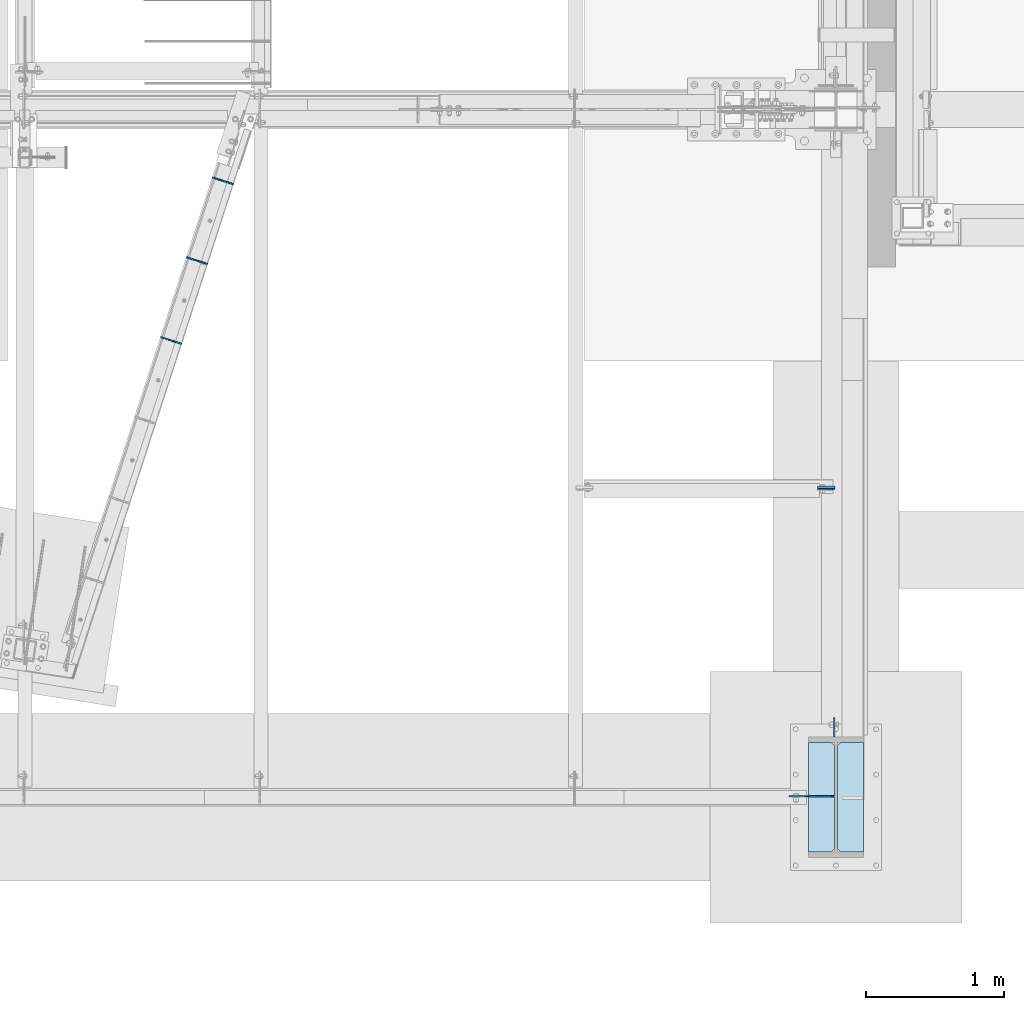
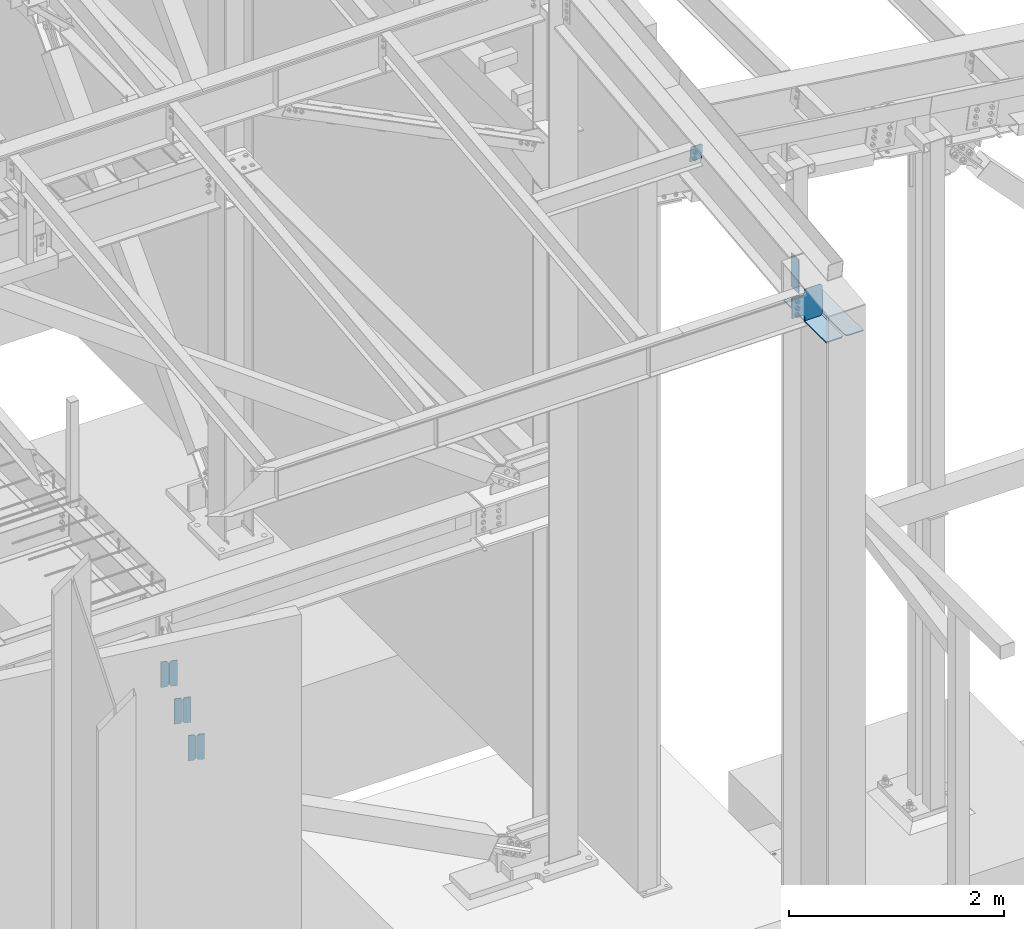
# One storey, part 1001 of 1179: 11 plates, 3 elements without a shape of their own.
"""IFC2X3 building model written with IfcOpenShell, lengths in millimetres."""

from ifc_helpers import new_model, si_unit, frame, origin_with_axes, place, context, subcontext, project, spatial, faceted_brep, material, type_object, element, aggregate, save


model = new_model("IFC2X3")

# Units and contexts
model_context = context("Model", 3, precision=1e-05, world=origin_with_axes())
body_context = subcontext(model_context, "Body", "Model", "MODEL_VIEW")
ifc_project = project(units=[si_unit("LENGTHUNIT", "METRE", prefix="MILLI"), si_unit("AREAUNIT", "SQUARE_METRE"), si_unit("VOLUMEUNIT", "CUBIC_METRE"), si_unit("MASSUNIT", "GRAM", prefix="KILO"), si_unit("TIMEUNIT", "SECOND"), si_unit("PLANEANGLEUNIT", "RADIAN"), si_unit("SOLIDANGLEUNIT", "STERADIAN"), si_unit("THERMODYNAMICTEMPERATUREUNIT", "DEGREE_CELSIUS"), si_unit("LUMINOUSINTENSITYUNIT", "LUMEN")], contexts=[model_context])

# Site, building, storey
site_placement = place(None, origin_with_axes())
site = spatial("IfcSite", under=ifc_project, at=site_placement, CompositionType="ELEMENT")
building_placement = place(site_placement, origin_with_axes())
building = spatial("IfcBuilding", under=site, at=building_placement, Name="Undefined", CompositionType="ELEMENT")
storey_placement = place(building_placement, origin_with_axes())
storey = spatial("IfcBuildingStorey", under=building, at=storey_placement, Name="Undefined", CompositionType="ELEMENT", Elevation=0.0)

# Assembly, plates
assembly_1_placement = place(storey_placement, origin_with_axes())
assembly_1 = element("IfcElementAssembly", 1, at=assembly_1_placement, inside=storey, Name="BEAM", AssemblyPlace="NOTDEFINED", PredefinedType="RIGID_FRAME")
ifc_material = material(Name="STEEL/A36")
plate_type_1 = type_object("IfcPlateType", PredefinedType="NOTDEFINED")
plate_1_placement = place(assembly_1_placement, frame((19553.647690554, 3732.85170850792, 3548.0625), z_axis=(0.0, 0.0, 1.0), x_axis=(-0.951147367197957, 0.308737244064262, 0.0)))
plate_1 = element("IfcPlate", 2, at=plate_1_placement, type_object=plate_type_1, material=ifc_material, Name="PLATE", context=body_context, shape_type="Brep", body=[
    faceted_brep([(0.0, -4.76249999999709, 0.0), (-3.63797880709171e-12, -4.76249999999709, 288.925000000003), (0.0, 4.76249999999891, 288.925000000003), (0.0, 4.76249999999709, 0.0), (57.150000763173, -4.76249999998345, 288.925), (57.1500007631694, 4.76250000001619, 288.925), (76.2000000002517, -4.7624999999789, 269.875000762939), (76.2000000002517, 4.76250000002165, 269.875000762939), (76.2000000002517, -4.7624999999789, 19.0499992370605), (76.2000000002517, 4.76250000002165, 19.0499992370605), (57.1500015258789, -4.76250000000073, 0.0), (57.1500015258789, 4.76250000000073, 0.0)], [[[0, 1, 2, 3]], [[1, 4, 5, 2]], [[4, 6, 7, 5]], [[6, 8, 9, 7]], [[8, 10, 11, 9]], [[10, 0, 3, 11]], [[5, 7, 9, 11, 3, 2]], [[10, 8, 6, 4, 1, 0]]]),
])
plate_2_placement = place(assembly_1_placement, frame((19475.1304753914, 3758.33796800497, 3548.0625), z_axis=(0.0, 0.0, 1.0), x_axis=(-0.951147367197957, 0.308737244064262, 0.0)))
plate_2 = element("IfcPlate", 3, at=plate_2_placement, type_object=plate_type_1, material=ifc_material, Name="PLATE", context=body_context, shape_type="Brep", body=[
    faceted_brep([(0.0, -4.76250000000073, 19.0499992370605), (0.0, -4.76249999999982, 269.875000762939), (0.0, 4.76249999999982, 269.875000762939), (0.0, 4.76250000000073, 19.0499992370605), (19.0499992370824, -4.76249999999527, 288.925), (19.0499992370824, 4.76250000000618, 288.925), (76.2000000002554, -4.76249999997799, 288.925), (76.2000000002554, 4.76250000002256, 288.925), (76.1999999999971, -4.76249999999999, 0.0), (76.1999999999971, 4.76249999999999, 0.0), (19.0499992370605, -4.76250000000073, 0.0), (19.0499992370605, 4.76250000000073, 0.0)], [[[0, 1, 2, 3]], [[1, 4, 5, 2]], [[4, 6, 7, 5]], [[6, 8, 9, 7]], [[8, 10, 11, 9]], [[10, 0, 3, 11]], [[5, 7, 9, 11, 3, 2]], [[10, 8, 6, 4, 1, 0]]]),
])
plate_3_placement = place(assembly_1_placement, frame((19741.8539145355, 4312.67114355146, 3548.0625), z_axis=(0.0, 0.0, 1.0), x_axis=(-0.951147367197957, 0.308737244064262, 0.0)))
plate_3 = element("IfcPlate", 4, at=plate_3_placement, type_object=plate_type_1, material=ifc_material, Name="PLATE", context=body_context, shape_type="Brep", body=[
    faceted_brep([(0.0, -4.76249999999709, 0.0), (-3.63797880709171e-12, -4.76249999999709, 288.925000000003), (0.0, 4.76249999999891, 288.925000000003), (0.0, 4.76249999999709, 0.0), (57.150000763173, -4.76249999998345, 288.925), (57.1500007631694, 4.76250000001619, 288.925), (76.2000000002517, -4.7624999999789, 269.875000762939), (76.2000000002517, 4.76250000002165, 269.875000762939), (76.2000000002517, -4.7624999999789, 19.0499992370605), (76.2000000002517, 4.76250000002165, 19.0499992370605), (57.1500015258789, -4.76250000000073, 0.0), (57.1500015258789, 4.76250000000073, 0.0)], [[[0, 1, 2, 3]], [[1, 4, 5, 2]], [[4, 6, 7, 5]], [[6, 8, 9, 7]], [[8, 10, 11, 9]], [[10, 0, 3, 11]], [[5, 7, 9, 11, 3, 2]], [[10, 8, 6, 4, 1, 0]]]),
])
plate_4_placement = place(assembly_1_placement, frame((19663.336699373, 4338.15740304899, 3548.0625), z_axis=(0.0, 0.0, 1.0), x_axis=(-0.951147367197957, 0.308737244064262, 0.0)))
plate_4 = element("IfcPlate", 5, at=plate_4_placement, type_object=plate_type_1, material=ifc_material, Name="PLATE", context=body_context, shape_type="Brep", body=[
    faceted_brep([(0.0, -4.76250000000073, 19.0499992370605), (0.0, -4.76249999999982, 269.875000762939), (0.0, 4.76249999999982, 269.875000762939), (0.0, 4.76250000000073, 19.0499992370605), (19.0499992370824, -4.76249999999527, 288.925), (19.0499992370824, 4.76250000000618, 288.925), (76.2000000002554, -4.76249999997799, 288.925), (76.2000000002554, 4.76250000002256, 288.925), (76.1999999999971, -4.76249999999999, 0.0), (76.1999999999971, 4.76249999999999, 0.0), (19.0499992370605, -4.76250000000073, 0.0), (19.0499992370605, 4.76250000000073, 0.0)], [[[0, 1, 2, 3]], [[1, 4, 5, 2]], [[4, 6, 7, 5]], [[6, 8, 9, 7]], [[8, 10, 11, 9]], [[10, 0, 3, 11]], [[5, 7, 9, 11, 3, 2]], [[10, 8, 6, 4, 1, 0]]]),
])
plate_5_placement = place(assembly_1_placement, frame((19930.0601385177, 4892.49057859528, 3548.0625), z_axis=(0.0, 0.0, 1.0), x_axis=(-0.951147367197957, 0.308737244064262, 0.0)))
plate_5 = element("IfcPlate", 6, at=plate_5_placement, type_object=plate_type_1, material=ifc_material, Name="PLATE", context=body_context, shape_type="Brep", body=[
    faceted_brep([(0.0, -4.76249999999709, 0.0), (-3.63797880709171e-12, -4.76249999999709, 288.925000000003), (0.0, 4.76249999999891, 288.925000000003), (0.0, 4.76249999999709, 0.0), (57.150000763173, -4.76249999998345, 288.925), (57.1500007631694, 4.76250000001619, 288.925), (76.2000000002517, -4.7624999999789, 269.875000762939), (76.2000000002517, 4.76250000002165, 269.875000762939), (76.2000000002517, -4.7624999999789, 19.0499992370605), (76.2000000002517, 4.76250000002165, 19.0499992370605), (57.1500015258789, -4.76250000000073, 0.0), (57.1500015258789, 4.76250000000073, 0.0)], [[[0, 1, 2, 3]], [[1, 4, 5, 2]], [[4, 6, 7, 5]], [[6, 8, 9, 7]], [[8, 10, 11, 9]], [[10, 0, 3, 11]], [[5, 7, 9, 11, 3, 2]], [[10, 8, 6, 4, 1, 0]]]),
])
plate_6_placement = place(assembly_1_placement, frame((19851.5429233554, 4917.97683809274, 3548.0625), z_axis=(0.0, 0.0, 1.0), x_axis=(-0.951147367197957, 0.308737244064262, 0.0)))
plate_6 = element("IfcPlate", 7, at=plate_6_placement, type_object=plate_type_1, material=ifc_material, Name="PLATE", context=body_context, shape_type="Brep", body=[
    faceted_brep([(0.0, -4.76250000000073, 19.0499992370605), (0.0, -4.76249999999982, 269.875000762939), (0.0, 4.76249999999982, 269.875000762939), (0.0, 4.76250000000073, 19.0499992370605), (19.0499992370824, -4.76249999999527, 288.925), (19.0499992370824, 4.76250000000618, 288.925), (76.2000000002554, -4.76249999997799, 288.925), (76.2000000002554, 4.76250000002256, 288.925), (76.1999999999971, -4.76249999999999, 0.0), (76.1999999999971, 4.76249999999999, 0.0), (19.0499992370605, -4.76250000000073, 0.0), (19.0499992370605, 4.76250000000073, 0.0)], [[[0, 1, 2, 3]], [[1, 4, 5, 2]], [[4, 6, 7, 5]], [[6, 8, 9, 7]], [[8, 10, 11, 9]], [[10, 0, 3, 11]], [[5, 7, 9, 11, 3, 2]], [[10, 8, 6, 4, 1, 0]]]),
])
aggregate(assembly_1, [plate_1, plate_2, plate_3, plate_4, plate_5, plate_6])

# Assembly, plate
assembly_2_placement = place(storey_placement, origin_with_axes())
assembly_2 = element("IfcElementAssembly", 8, at=assembly_2_placement, inside=storey, Name="BEAM", AssemblyPlace="NOTDEFINED", PredefinedType="RIGID_FRAME")
plate_type_2 = type_object("IfcPlateType", PredefinedType="NOTDEFINED")
plate_7_placement = place(assembly_2_placement, frame((24300.65625, 2676.77209041625, 9525.39654034292), z_axis=(-1.0, 0.0, 0.0), x_axis=(0.0, 0.112284087038014, -0.993676146336441)))
plate_7 = element("IfcPlate", 9, at=plate_7_placement, type_object=plate_type_2, material=ifc_material, Name="PLATE", context=body_context, shape_type="Brep", body=[
    faceted_brep([(0.0, -4.76250000000073, 19.0499992370605), (-3.63797880709171e-12, -4.76249999999709, 127.793749999997), (0.0, 4.76250000000437, 127.793749999997), (0.0, 4.76250000000073, 19.0499992370605), (179.387499999706, -4.762500000008, 127.793750000001), (179.387499999702, 4.76249999999072, 127.793750000001), (179.387499999706, -4.762500000008, 0.0), (179.387499999702, 4.76249999999072, 0.0), (19.0499992370605, -4.76250000000073, 0.0), (19.0499992370605, 4.76250000000073, 0.0)], [[[0, 1, 2, 3]], [[1, 4, 5, 2]], [[4, 6, 7, 5]], [[6, 8, 9, 7]], [[8, 0, 3, 9]], [[5, 7, 9, 3, 2]], [[8, 6, 4, 1, 0]]]),
])
aggregate(assembly_2, [plate_7])

# Assembly, plates
assembly_3_placement = place(storey_placement, origin_with_axes())
assembly_3 = element("IfcElementAssembly", 10, at=assembly_3_placement, inside=storey, Name="COLUMN", AssemblyPlace="NOTDEFINED", PredefinedType="RIGID_FRAME")
plate_type_3 = type_object("IfcPlateType", PredefinedType="NOTDEFINED")
plate_8_placement = place(assembly_3_placement, frame((24295.89375, 876.299999999866, 9291.80837908503), z_axis=(0.0, 1.0, 0.0), x_axis=(0.0, 0.0, -1.0)))
plate_8 = element("IfcPlate", 11, at=plate_8_placement, type_object=plate_type_3, material=ifc_material, Name="PLATE", context=body_context, shape_type="Brep", body=[
    faceted_brep([(0.0, -4.76249999999709, 0.0), (0.0, -4.76249999999982, 139.699999999997), (0.0, 4.76249999999982, 139.699999999997), (0.0, 4.76249999999709, 0.0), (381.000000000031, -4.76249999999999, 139.700000000086), (381.000000000031, 4.76249999999999, 139.700000000086), (381.0, -4.76249999999999, 8.66293703438714e-11), (381.0, 4.76249999999999, 8.66293703438714e-11)], [[[0, 1, 2, 3]], [[1, 4, 5, 2]], [[4, 6, 7, 5]], [[6, 0, 3, 7]], [[5, 7, 3, 2]], [[6, 4, 1, 0]]]),
])
plate_type_4 = type_object("IfcPlateType", PredefinedType="NOTDEFINED")
plate_9_placement = place(assembly_3_placement, frame((24318.9125, 835.025, 8922.35966887871), z_axis=(0.0, -1.0, 0.0), x_axis=(1.0, 0.0, 0.0)))
plate_9 = element("IfcPlate", 12, at=plate_9_placement, type_object=plate_type_4, material=ifc_material, Name="PLATE", context=body_context, shape_type="Brep", body=[
    faceted_brep([(0.0, -6.34999999999854, 22.2250003814697), (0.0, -6.35000000000036, 771.52499961853), (0.0, 6.35000000000036, 771.52499961853), (0.0, 6.34999999999854, 22.2250003814697), (22.2250003814697, -6.35000000000036, 793.75), (22.2250003814697, 6.35000000000036, 793.75), (188.912500000002, -6.35000000000036, 793.75), (188.912500000002, 6.35000000000036, 793.75), (188.912500000002, -6.35000000000036, 0.0), (188.912500000002, 6.35000000000036, 0.0), (22.2250003814697, -6.34999999999854, 0.0), (22.2250003814697, 6.34999999999854, 0.0)], [[[0, 1, 2, 3]], [[1, 4, 5, 2]], [[4, 6, 7, 5]], [[6, 8, 9, 7]], [[8, 10, 11, 9]], [[10, 0, 3, 11]], [[5, 7, 9, 11, 3, 2]], [[10, 8, 6, 4, 1, 0]]]),
])
plate_10_placement = place(assembly_3_placement, frame((24107.775, 835.025, 8922.35966887871), z_axis=(0.0, -1.0, 0.0), x_axis=(1.0, 0.0, 0.0)))
plate_10 = element("IfcPlate", 13, at=plate_10_placement, type_object=plate_type_4, material=ifc_material, Name="PLATE", context=body_context, shape_type="Brep", body=[
    faceted_brep([(0.0, -6.34999999999854, 0.0), (0.0, -6.35000000000036, 793.75), (0.0, 6.35000000000036, 793.75), (0.0, 6.34999999999854, 0.0), (166.687499618532, -6.35000000000036, 793.75), (166.687499618532, 6.35000000000036, 793.75), (188.912500000002, -6.35000000000036, 771.52499961853), (188.912500000002, 6.35000000000036, 771.52499961853), (188.912500000002, -6.35000000000036, 22.2250003814697), (188.912500000002, 6.35000000000036, 22.2250003814697), (166.687499618532, -6.35000000000036, 0.0), (166.687499618532, 6.35000000000036, 0.0)], [[[0, 1, 2, 3]], [[1, 4, 5, 2]], [[4, 6, 7, 5]], [[6, 8, 9, 7]], [[8, 10, 11, 9]], [[10, 0, 3, 11]], [[5, 7, 9, 11, 3, 2]], [[10, 8, 6, 4, 1, 0]]]),
])
plate_type_5 = type_object("IfcPlateType", PredefinedType="NOTDEFINED")
plate_11_placement = place(assembly_3_placement, frame((24296.6875, 446.08749988271, 8947.75966887871), z_axis=(-0.707106781186532, 0.0, 0.707106781186563), x_axis=(-0.707106781186564, 0.0, -0.707106781186531)))
plate_11 = element("IfcPlate", 14, at=plate_11_placement, type_object=plate_type_5, material=ifc_material, Name="PLATE", context=body_context, shape_type="Brep", body=[
    faceted_brep([(0.0, -4.76249999999709, 0.0), (-226.470816375611, -4.76249999999999, 226.470816375618), (-226.470816375611, 4.76249999999999, 226.470816375618), (0.0, 4.76249999999709, 0.0), (-226.470816375654, -4.76249999999999, 253.411584738797), (-226.470816375654, 4.76249999999999, 253.411584738797), (-106.359890756637, -4.76249999999999, 373.52251035781), (-106.359890756637, 4.76249999999999, 373.52251035781), (-81.9448368353978, -4.76249999999999, 349.107456436569), (-81.9448368353978, 4.76249999999999, 349.107456436569), (-73.7044838990896, -4.76249999999999, 343.601428635614), (-73.7044838990896, 4.76249999999999, 343.601428635614), (-63.9843248629977, -4.76249999999999, 341.667968790437), (-63.9843248629977, 4.76249999999999, 341.667968790437), (-54.2641658269058, -4.76249999999999, 343.601428635612), (-54.2641658269058, 4.76249999999999, 343.601428635612), (-46.0238128905976, -4.76249999999999, 349.107456436567), (-46.0238128905976, 4.76249999999999, 349.107456436567), (34.798492468527, -4.76249999999999, 429.929761795689), (34.798492468527, 4.76249999999999, 429.929761795689), (196.443102647823, -4.76249999999999, 268.285151616388), (196.443102647823, 4.76249999999999, 268.285151616388), (115.620797288699, -4.76249999999999, 187.462846257265), (115.620797288699, 4.76249999999999, 187.462846257265), (110.114769487744, -4.76249999999999, 179.222493320958), (110.114769487744, 4.76249999999999, 179.222493320958), (108.181309642569, -4.76249999999999, 169.502334284865), (108.181309642569, 4.76249999999999, 169.502334284865), (110.114769487745, -4.76249999999999, 159.782175248773), (110.114769487745, 4.76249999999999, 159.782175248773), (115.620797288702, -4.76249999999999, 151.541822312464), (115.620797288702, 4.76249999999999, 151.541822312464), (147.051693982197, -4.76249999999999, 120.110925618969), (147.051693982197, 4.76249999999999, 120.110925618969), (26.9407683631525, -4.76249999999709, -6.18456397205591e-11), (26.9407683631525, 4.76249999999709, -6.18456397205591e-11)], [[[0, 1, 2, 3]], [[1, 4, 5, 2]], [[4, 6, 7, 5]], [[6, 8, 9, 7]], [[8, 10, 11, 9]], [[10, 12, 13, 11]], [[12, 14, 15, 13]], [[14, 16, 17, 15]], [[16, 18, 19, 17]], [[18, 20, 21, 19]], [[20, 22, 23, 21]], [[22, 24, 25, 23]], [[24, 26, 27, 25]], [[26, 28, 29, 27]], [[28, 30, 31, 29]], [[30, 32, 33, 31]], [[32, 34, 35, 33]], [[34, 0, 3, 35]], [[5, 7, 9, 11, 13, 15, 17, 19, 21, 23, 25, 27, 29, 31, 33, 35, 3, 2]], [[34, 32, 30, 28, 26, 24, 22, 20, 18, 16, 14, 12, 10, 8, 6, 4, 1, 0]]]),
])
aggregate(assembly_3, [plate_8, plate_9, plate_10, plate_11])

save(model, "model.ifc")
